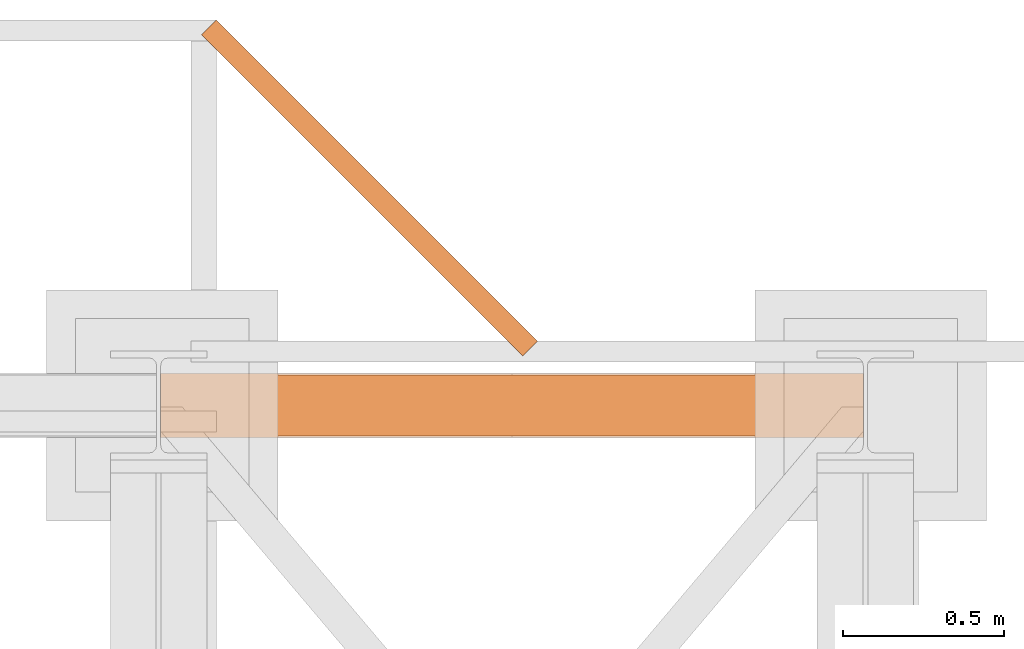
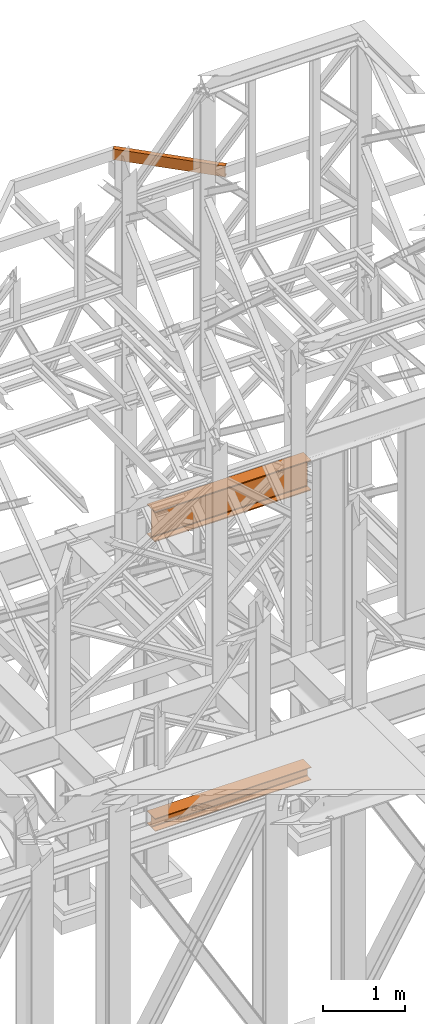
# One storey, part 197 of 208: 3 proxies.
"""IFC2X3 building model written with IfcOpenShell, lengths in millimetres."""

from ifc_helpers import new_model, entity, si_unit, converted_unit, frame, origin, origin_with_axes, place, context, subcontext, project, spatial, faceted_brep, element, save


model = new_model("IFC2X3")

# Units and contexts
model_context = context("Model", 3, precision=1e-05, world=origin())
plan_context = context("Plan", 3, precision=1e-05, world=origin())
body_context = subcontext(model_context, "Body", "Model", "MODEL_VIEW")
ifc_project = project(units=[si_unit("LENGTHUNIT", "METRE", prefix="MILLI"), converted_unit("PLANEANGLEUNIT", "DEGREE", entity("IfcPlaneAngleMeasure", 0.0174532925199433), si_unit("PLANEANGLEUNIT", "RADIAN"), dimensions=[0, 0, 0, 0, 0, 0, 0]), si_unit("AREAUNIT", "SQUARE_METRE"), si_unit("VOLUMEUNIT", "CUBIC_METRE")], contexts=[model_context, plan_context])

# Building, storey
building_placement = place(None, origin())
building = spatial("IfcBuilding", under=ifc_project, at=building_placement, CompositionType="COMPLEX")
storey_placement = place(building_placement, origin_with_axes())
storey = spatial("IfcBuildingStorey", under=building, at=storey_placement, Name="Geschoss", CompositionType="ELEMENT")

# Proxies
proxy_1_placement = place(storey_placement, frame((6599.254968580823, -12562.57439501764, 544.9900024165573), z_axis=(0.0, 0.0, 1.0), x_axis=(1.0, 0.0, 0.0)))
element("IfcBuildingElementProxy", 1, at=proxy_1_placement, inside=storey, context=body_context, shape_type="Brep", body=[
    faceted_brep([(2188.00999989569, 0.01000000000021828, 190.0100125169755), (2188.00999989569, 200.0100029802325, 190.0100125169755), (2188.00999989569, 200.0100029802325, 180.0100146031381), (2188.00999989569, 121.2600035762789, 180.0100071525575), (2188.00999989569, 111.9441915473344, 178.1454621052743), (2188.00999989569, 105.1245498640838, 171.3258190250398), (2188.00999989569, 103.2600015571716, 162.0100079274179), (2188.00999989569, 103.2600015571716, 28.00999713897716), (2188.00999989569, 105.1245498640838, 18.69418604135524), (2188.00999989569, 111.9441915473344, 11.87454296112071), (2188.00999989569, 121.2600035762789, 10.00999791383754), (2188.00999989569, 200.0100029802325, 10.00999791383754), (2188.00999989569, 200.0100029802325, 0.01000000000010459), (2188.00999989569, 0.01000000000021828, 0.01000000000010459), (2188.00999989569, 0.01000000000021828, 10.00999791383754), (2188.00999989569, 78.75999940395377, 10.00999791383754), (2188.00999989569, 88.07581143289826, 11.87454296112071), (2188.00999989569, 94.89545311614893, 18.69418604135524), (2188.00999989569, 96.76000142306111, 28.00999713897716), (2188.00999989569, 96.76000142306111, 162.0100079274179), (2188.00999989569, 94.89545311614893, 171.3258190250398), (2188.00999989569, 88.07581143289826, 178.1454621052743), (2188.00999989569, 78.75999940395377, 180.0100071525575), (2188.00999989569, 0.01000000000021828, 180.0100146031381), (2188.00999989569, 200.0100029802325, 190.0100125169755), (2188.00999989569, 0.01000000000021828, 190.0100125169755), (0.01000000000021828, 0.01000000000021828, 190.0100125169754), (0.01000000000021828, 200.0100029802325, 190.0100125169754), (2188.00999989569, 200.0100029802325, 180.0100146031381), (2188.00999989569, 200.0100029802325, 190.0100125169755), (0.01000000000021828, 200.0100029802325, 190.0100125169754), (0.01000000000021828, 200.0100029802325, 180.010014603138), (2188.00999989569, 121.2600035762789, 180.0100071525575), (2188.00999989569, 200.0100029802325, 180.0100146031381), (0.01000000000021828, 200.0100029802325, 180.010014603138), (0.01000000000021828, 121.2600035762789, 180.0100071525574), (2188.00999989569, 111.9441915473344, 178.1454621052743), (2188.00999989569, 121.2600035762789, 180.0100071525575), (0.01000000000021828, 121.2600035762789, 180.0100071525574), (0.01000000000021828, 111.9441915473344, 178.1454621052742), (2188.00999989569, 105.1245498640838, 171.3258190250398), (2188.00999989569, 111.9441915473344, 178.1454621052743), (0.01000000000021828, 111.9441915473344, 178.1454621052742), (0.01000000000021828, 105.1245498640838, 171.3258190250397), (2188.00999989569, 103.2600015571716, 162.0100079274179), (2188.00999989569, 105.1245498640838, 171.3258190250398), (0.01000000000021828, 105.1245498640838, 171.3258190250397), (0.01000000000021828, 103.2600015571716, 162.0100079274178), (2188.00999989569, 103.2600015571716, 28.00999713897716), (2188.00999989569, 103.2600015571716, 162.0100079274179), (0.01000000000021828, 103.2600015571716, 162.0100079274178), (0.01000000000021828, 103.2600015571716, 28.00999713897704), (2188.00999989569, 105.1245498640838, 18.69418604135524), (2188.00999989569, 103.2600015571716, 28.00999713897716), (0.01000000000021828, 103.2600015571716, 28.00999713897704), (0.01000000000021828, 105.1245498640838, 18.69418604135512), (2188.00999989569, 111.9441915473344, 11.87454296112071), (2188.00999989569, 105.1245498640838, 18.69418604135524), (0.01000000000021828, 105.1245498640838, 18.69418604135512), (0.01000000000021828, 111.9441915473344, 11.8745429611206), (2188.00999989569, 121.2600035762789, 10.00999791383754), (2188.00999989569, 111.9441915473344, 11.87454296112071), (0.01000000000021828, 111.9441915473344, 11.8745429611206), (0.01000000000021828, 121.2600035762789, 10.00999791383742), (2188.00999989569, 200.0100029802325, 10.00999791383754), (2188.00999989569, 121.2600035762789, 10.00999791383754), (0.01000000000021828, 121.2600035762789, 10.00999791383742), (0.01000000000021828, 200.0100029802325, 10.00999791383742), (2188.00999989569, 200.0100029802325, 0.01000000000010459), (2188.00999989569, 200.0100029802325, 10.00999791383754), (0.01000000000021828, 200.0100029802325, 10.00999791383742), (0.01000000000021828, 200.0100029802325, 0.009999999999990905), (2188.00999989569, 0.01000000000021828, 0.01000000000010459), (2188.00999989569, 200.0100029802325, 0.01000000000010459), (0.01000000000021828, 200.0100029802325, 0.009999999999990905), (0.01000000000021828, 0.01000000000021828, 0.009999999999990905), (2188.00999989569, 0.01000000000021828, 10.00999791383754), (2188.00999989569, 0.01000000000021828, 0.01000000000010459), (0.01000000000021828, 0.01000000000021828, 0.009999999999990905), (0.01000000000021828, 0.01000000000021828, 10.00999791383742), (2188.00999989569, 78.75999940395377, 10.00999791383754), (2188.00999989569, 0.01000000000021828, 10.00999791383754), (0.01000000000021828, 0.01000000000021828, 10.00999791383742), (0.01000000000021828, 78.75999940395377, 10.00999791383742), (2188.00999989569, 88.07581143289826, 11.87454296112071), (2188.00999989569, 78.75999940395377, 10.00999791383754), (0.01000000000021828, 78.75999940395377, 10.00999791383742), (0.01000000000021828, 88.07581143289826, 11.8745429611206), (2188.00999989569, 94.89545311614893, 18.69418604135524), (2188.00999989569, 88.07581143289826, 11.87454296112071), (0.01000000000021828, 88.07581143289826, 11.8745429611206), (0.01000000000021828, 94.89545311614893, 18.69418604135512), (2188.00999989569, 96.76000142306111, 28.00999713897716), (2188.00999989569, 94.89545311614893, 18.69418604135524), (0.01000000000021828, 94.89545311614893, 18.69418604135512), (0.01000000000021828, 96.76000142306111, 28.00999713897704), (2188.00999989569, 96.76000142306111, 162.0100079274179), (2188.00999989569, 96.76000142306111, 28.00999713897716), (0.01000000000021828, 96.76000142306111, 28.00999713897704), (0.01000000000021828, 96.76000142306111, 162.0100079274178), (2188.00999989569, 94.89545311614893, 171.3258190250398), (2188.00999989569, 96.76000142306111, 162.0100079274179), (0.01000000000021828, 96.76000142306111, 162.0100079274178), (0.01000000000021828, 94.89545311614893, 171.3258190250397), (2188.00999989569, 88.07581143289826, 178.1454621052743), (2188.00999989569, 94.89545311614893, 171.3258190250398), (0.01000000000021828, 94.89545311614893, 171.3258190250397), (0.01000000000021828, 88.07581143289826, 178.1454621052742), (2188.00999989569, 78.75999940395377, 180.0100071525575), (2188.00999989569, 88.07581143289826, 178.1454621052743), (0.01000000000021828, 88.07581143289826, 178.1454621052742), (0.01000000000021828, 78.75999940395377, 180.0100071525574), (2188.00999989569, 0.01000000000021828, 180.0100146031381), (2188.00999989569, 78.75999940395377, 180.0100071525575), (0.01000000000021828, 78.75999940395377, 180.0100071525574), (0.01000000000021828, 0.01000000000021828, 180.010014603138), (2188.00999989569, 0.01000000000021828, 190.0100125169755), (2188.00999989569, 0.01000000000021828, 180.0100146031381), (0.01000000000021828, 0.01000000000021828, 180.010014603138), (0.01000000000021828, 0.01000000000021828, 190.0100125169754), (0.01000000000021828, 0.01000000000021828, 190.0100125169754), (0.01000000000021828, 0.01000000000021828, 180.010014603138), (0.01000000000021828, 78.75999940395377, 180.0100071525574), (0.01000000000021828, 88.07581143289826, 178.1454621052742), (0.01000000000021828, 94.89545311614893, 171.3258190250397), (0.01000000000021828, 96.76000142306111, 162.0100079274178), (0.01000000000021828, 96.76000142306111, 28.00999713897704), (0.01000000000021828, 94.89545311614893, 18.69418604135512), (0.01000000000021828, 88.07581143289826, 11.8745429611206), (0.01000000000021828, 78.75999940395377, 10.00999791383742), (0.01000000000021828, 0.01000000000021828, 10.00999791383742), (0.01000000000021828, 0.01000000000021828, 0.009999999999990905), (0.01000000000021828, 200.0100029802325, 0.009999999999990905), (0.01000000000021828, 200.0100029802325, 10.00999791383742), (0.01000000000021828, 121.2600035762789, 10.00999791383742), (0.01000000000021828, 111.9441915473344, 11.8745429611206), (0.01000000000021828, 105.1245498640838, 18.69418604135512), (0.01000000000021828, 103.2600015571716, 28.00999713897704), (0.01000000000021828, 103.2600015571716, 162.0100079274178), (0.01000000000021828, 105.1245498640838, 171.3258190250397), (0.01000000000021828, 111.9441915473344, 178.1454621052742), (0.01000000000021828, 121.2600035762789, 180.0100071525574), (0.01000000000021828, 200.0100029802325, 180.010014603138), (0.01000000000021828, 200.0100029802325, 190.0100125169754)], [[[0, 1, 2, 3, 4, 5, 6, 7, 8, 9, 10, 11, 12, 13, 14, 15, 16, 17, 18, 19, 20, 21, 22, 23]], [[24, 25, 26, 27]], [[28, 29, 30, 31]], [[32, 33, 34, 35]], [[36, 37, 38, 39]], [[40, 41, 42, 43]], [[44, 45, 46, 47]], [[48, 49, 50, 51]], [[52, 53, 54, 55]], [[56, 57, 58, 59]], [[60, 61, 62, 63]], [[64, 65, 66, 67]], [[68, 69, 70, 71]], [[72, 73, 74, 75]], [[76, 77, 78, 79]], [[80, 81, 82, 83]], [[84, 85, 86, 87]], [[88, 89, 90, 91]], [[92, 93, 94, 95]], [[96, 97, 98, 99]], [[100, 101, 102, 103]], [[104, 105, 106, 107]], [[108, 109, 110, 111]], [[112, 113, 114, 115]], [[116, 117, 118, 119]], [[120, 121, 122, 123, 124, 125, 126, 127, 128, 129, 130, 131, 132, 133, 134, 135, 136, 137, 138, 139, 140, 141, 142, 143]]], orient=[[False], [False], [False], [False], [False], [False], [False], [False], [False], [False], [False], [False], [False], [False], [False], [False], [False], [False], [False], [False], [False], [False], [False], [False], [False], [False]]),
])
proxy_2_placement = place(storey_placement, frame((6599.254968580832, -12557.574399786, 4834.989987483023), z_axis=(0.0, 0.0, 1.0), x_axis=(1.0, 0.0, 0.0)))
element("IfcBuildingElementProxy", 2, at=proxy_2_placement, inside=storey, context=body_context, shape_type="Brep", body=[
    faceted_brep([(2188.009999895692, 0.00999999999839929, 450.0100178813937), (2188.009999895692, 190.0100125169738, 450.0100178813937), (2188.009999895692, 190.0100125169738, 435.4100240564349), (2188.009999895692, 120.7100073045476, 435.4100091552737), (2188.009999895692, 109.8415622657522, 433.2347078418734), (2188.009999895692, 101.8853126263603, 425.2784563398363), (2188.009999895692, 99.71000619068582, 414.4100113010409), (2188.009999895692, 99.71000619068582, 35.60999167919181), (2188.009999895692, 101.8853126263603, 24.74154664039634), (2188.009999895692, 109.8415622657522, 16.78529513835929), (2188.009999895692, 120.7100073045476, 14.60999382495902), (2188.009999895692, 190.0100125169738, 14.60999382495902), (2188.009999895692, 190.0100125169738, 0.01000000000021828), (2188.009999895692, 0.00999999999839929, 0.01000000000021828), (2188.009999895692, 0.00999999999839929, 14.60999382495902), (2188.009999895692, 69.31000521242458, 14.60999382495902), (2188.009999895692, 80.17845025122006, 16.78529513835929), (2188.009999895692, 88.13469989061196, 24.74154664039634), (2188.009999895692, 90.31000632628638, 35.60999167919181), (2188.009999895692, 90.31000632628638, 414.4100113010409), (2188.009999895692, 88.13469989061196, 425.2784563398363), (2188.009999895692, 80.17845025122006, 433.2347078418734), (2188.009999895692, 69.31000521242458, 435.4100091552737), (2188.009999895692, 0.00999999999839929, 435.4100240564349), (2188.009999895692, 190.0100125169738, 450.0100178813937), (2188.009999895692, 0.00999999999839929, 450.0100178813937), (0.01000000000021828, 0.01000000000021828, 450.0100178813937), (0.01000000000021828, 190.0100125169756, 450.0100178813937), (2188.009999895692, 190.0100125169738, 435.4100240564349), (2188.009999895692, 190.0100125169738, 450.0100178813937), (0.01000000000021828, 190.0100125169756, 450.0100178813937), (0.01000000000021828, 190.0100125169756, 435.4100240564349), (2188.009999895692, 120.7100073045476, 435.4100091552737), (2188.009999895692, 190.0100125169738, 435.4100240564349), (0.01000000000021828, 190.0100125169756, 435.4100240564349), (0.01000000000021828, 120.7100073045494, 435.4100091552737), (2188.009999895692, 109.8415622657522, 433.2347078418734), (2188.009999895692, 120.7100073045476, 435.4100091552737), (0.01000000000021828, 120.7100073045494, 435.4100091552737), (0.01000000000021828, 109.841562265754, 433.2347078418734), (2188.009999895692, 101.8853126263603, 425.2784563398363), (2188.009999895692, 109.8415622657522, 433.2347078418734), (0.01000000000021828, 109.841562265754, 433.2347078418734), (0.01000000000021828, 101.8853126263621, 425.2784563398363), (2188.009999895692, 99.71000619068582, 414.4100113010409), (2188.009999895692, 101.8853126263603, 425.2784563398363), (0.01000000000021828, 101.8853126263621, 425.2784563398363), (0.01000000000021828, 99.71000619068764, 414.4100113010409), (2188.009999895692, 99.71000619068582, 35.60999167919181), (2188.009999895692, 99.71000619068582, 414.4100113010409), (0.01000000000021828, 99.71000619068764, 414.4100113010409), (0.01000000000021828, 99.71000619068764, 35.60999167919181), (2188.009999895692, 101.8853126263603, 24.74154664039634), (2188.009999895692, 99.71000619068582, 35.60999167919181), (0.01000000000021828, 99.71000619068764, 35.60999167919181), (0.01000000000021828, 101.8853126263621, 24.74154664039634), (2188.009999895692, 109.8415622657522, 16.78529513835929), (2188.009999895692, 101.8853126263603, 24.74154664039634), (0.01000000000021828, 101.8853126263621, 24.74154664039634), (0.01000000000021828, 109.841562265754, 16.78529513835929), (2188.009999895692, 120.7100073045476, 14.60999382495902), (2188.009999895692, 109.8415622657522, 16.78529513835929), (0.01000000000021828, 109.841562265754, 16.78529513835929), (0.01000000000021828, 120.7100073045494, 14.60999382495902), (2188.009999895692, 190.0100125169738, 14.60999382495902), (2188.009999895692, 120.7100073045476, 14.60999382495902), (0.01000000000021828, 120.7100073045494, 14.60999382495902), (0.01000000000021828, 190.0100125169756, 14.60999382495902), (2188.009999895692, 190.0100125169738, 0.01000000000021828), (2188.009999895692, 190.0100125169738, 14.60999382495902), (0.01000000000021828, 190.0100125169756, 14.60999382495902), (0.01000000000021828, 190.0100125169756, 0.01000000000021828), (2188.009999895692, 0.00999999999839929, 0.01000000000021828), (2188.009999895692, 190.0100125169738, 0.01000000000021828), (0.01000000000021828, 190.0100125169756, 0.01000000000021828), (0.01000000000021828, 0.01000000000021828, 0.01000000000021828), (2188.009999895692, 0.00999999999839929, 14.60999382495902), (2188.009999895692, 0.00999999999839929, 0.01000000000021828), (0.01000000000021828, 0.01000000000021828, 0.01000000000021828), (0.01000000000021828, 0.01000000000021828, 14.60999382495902), (2188.009999895692, 69.31000521242458, 14.60999382495902), (2188.009999895692, 0.00999999999839929, 14.60999382495902), (0.01000000000021828, 0.01000000000021828, 14.60999382495902), (0.01000000000021828, 69.3100052124264, 14.60999382495902), (2188.009999895692, 80.17845025122006, 16.78529513835929), (2188.009999895692, 69.31000521242458, 14.60999382495902), (0.01000000000021828, 69.3100052124264, 14.60999382495902), (0.01000000000021828, 80.17845025122188, 16.78529513835929), (2188.009999895692, 88.13469989061196, 24.74154664039634), (2188.009999895692, 80.17845025122006, 16.78529513835929), (0.01000000000021828, 80.17845025122188, 16.78529513835929), (0.01000000000021828, 88.13469989061377, 24.74154664039634), (2188.009999895692, 90.31000632628638, 35.60999167919181), (2188.009999895692, 88.13469989061196, 24.74154664039634), (0.01000000000021828, 88.13469989061377, 24.74154664039634), (0.01000000000021828, 90.3100063262882, 35.60999167919181), (2188.009999895692, 90.31000632628638, 414.4100113010409), (2188.009999895692, 90.31000632628638, 35.60999167919181), (0.01000000000021828, 90.3100063262882, 35.60999167919181), (0.01000000000021828, 90.3100063262882, 414.4100113010409), (2188.009999895692, 88.13469989061196, 425.2784563398363), (2188.009999895692, 90.31000632628638, 414.4100113010409), (0.01000000000021828, 90.3100063262882, 414.4100113010409), (0.01000000000021828, 88.13469989061377, 425.2784563398363), (2188.009999895692, 80.17845025122006, 433.2347078418734), (2188.009999895692, 88.13469989061196, 425.2784563398363), (0.01000000000021828, 88.13469989061377, 425.2784563398363), (0.01000000000021828, 80.17845025122188, 433.2347078418734), (2188.009999895692, 69.31000521242458, 435.4100091552737), (2188.009999895692, 80.17845025122006, 433.2347078418734), (0.01000000000021828, 80.17845025122188, 433.2347078418734), (0.01000000000021828, 69.3100052124264, 435.4100091552737), (2188.009999895692, 0.00999999999839929, 435.4100240564349), (2188.009999895692, 69.31000521242458, 435.4100091552737), (0.01000000000021828, 69.3100052124264, 435.4100091552737), (0.01000000000021828, 0.01000000000021828, 435.4100240564349), (2188.009999895692, 0.00999999999839929, 450.0100178813937), (2188.009999895692, 0.00999999999839929, 435.4100240564349), (0.01000000000021828, 0.01000000000021828, 435.4100240564349), (0.01000000000021828, 0.01000000000021828, 450.0100178813937), (0.01000000000021828, 0.01000000000021828, 450.0100178813937), (0.01000000000021828, 0.01000000000021828, 435.4100240564349), (0.01000000000021828, 69.3100052124264, 435.4100091552737), (0.01000000000021828, 80.17845025122188, 433.2347078418734), (0.01000000000021828, 88.13469989061377, 425.2784563398363), (0.01000000000021828, 90.3100063262882, 414.4100113010409), (0.01000000000021828, 90.3100063262882, 35.60999167919181), (0.01000000000021828, 88.13469989061377, 24.74154664039634), (0.01000000000021828, 80.17845025122188, 16.78529513835929), (0.01000000000021828, 69.3100052124264, 14.60999382495902), (0.01000000000021828, 0.01000000000021828, 14.60999382495902), (0.01000000000021828, 0.01000000000021828, 0.01000000000021828), (0.01000000000021828, 190.0100125169756, 0.01000000000021828), (0.01000000000021828, 190.0100125169756, 14.60999382495902), (0.01000000000021828, 120.7100073045494, 14.60999382495902), (0.01000000000021828, 109.841562265754, 16.78529513835929), (0.01000000000021828, 101.8853126263621, 24.74154664039634), (0.01000000000021828, 99.71000619068764, 35.60999167919181), (0.01000000000021828, 99.71000619068764, 414.4100113010409), (0.01000000000021828, 101.8853126263621, 425.2784563398363), (0.01000000000021828, 109.841562265754, 433.2347078418734), (0.01000000000021828, 120.7100073045494, 435.4100091552737), (0.01000000000021828, 190.0100125169756, 435.4100240564349), (0.01000000000021828, 190.0100125169756, 450.0100178813937)], [[[0, 1, 2, 3, 4, 5, 6, 7, 8, 9, 10, 11, 12, 13, 14, 15, 16, 17, 18, 19, 20, 21, 22, 23]], [[24, 25, 26, 27]], [[28, 29, 30, 31]], [[32, 33, 34, 35]], [[36, 37, 38, 39]], [[40, 41, 42, 43]], [[44, 45, 46, 47]], [[48, 49, 50, 51]], [[52, 53, 54, 55]], [[56, 57, 58, 59]], [[60, 61, 62, 63]], [[64, 65, 66, 67]], [[68, 69, 70, 71]], [[72, 73, 74, 75]], [[76, 77, 78, 79]], [[80, 81, 82, 83]], [[84, 85, 86, 87]], [[88, 89, 90, 91]], [[92, 93, 94, 95]], [[96, 97, 98, 99]], [[100, 101, 102, 103]], [[104, 105, 106, 107]], [[108, 109, 110, 111]], [[112, 113, 114, 115]], [[116, 117, 118, 119]], [[120, 121, 122, 123, 124, 125, 126, 127, 128, 129, 130, 131, 132, 133, 134, 135, 136, 137, 138, 139, 140, 141, 142, 143]]], orient=[[False], [False], [False], [False], [False], [False], [False], [False], [False], [False], [False], [False], [False], [False], [False], [False], [False], [False], [False], [False], [False], [False], [False], [False], [False], [False]]),
])
proxy_3_placement = place(storey_placement, frame((6727.287533549237, -12308.53083325528, 9699.99), z_axis=(0.0, 0.0, 1.0), x_axis=(1.0, 0.0, 0.0)))
element("IfcBuildingElementProxy", 3, at=proxy_3_placement, inside=storey, context=body_context, shape_type="Brep", body=[
    faceted_brep([(45.97743646954586, 1045.966444427506, 0.01000000000021828), (1045.738309755405, 45.96644442750221, 0.01000000000021828), (1045.738309755405, 45.96644442750221, 3.132428070246533), (45.97743646954586, 1045.966444427506, 3.132428070246533), (45.97743646954586, 1045.966444427506, 3.132428070246533), (1045.738309755405, 45.96644442750221, 3.132428070246533), (1045.566648552481, 45.79482427335825, 4.748288908171162), (45.80577526662273, 1045.794824273362, 4.748288908171162), (45.80577526662273, 1045.794824273362, 4.748288908171162), (1045.566648552481, 45.79482427335825, 4.748288908171162), (1045.066854419561, 45.29514965456838, 6.221534443444398), (45.30598113370434, 1045.295149654572, 6.221534443444398), (45.30598113370434, 1045.295149654572, 6.221534443444398), (1045.066854419561, 45.29514965456838, 6.221534443444398), (1044.283017235056, 44.51149990647355, 7.422126703873801), (44.52214394919793, 1044.511499906475, 7.422126703873801), (44.52214394919793, 1044.511499906475, 7.422126703873801), (1044.283017235056, 44.51149990647355, 7.422126703873801), (1043.284325013841, 43.51304649924714, 8.244091391710754), (43.52345172798232, 1043.513046499251, 8.244091391710754), (43.52345172798232, 1043.513046499251, 8.244091391710754), (1043.284325013841, 43.51304649924714, 8.244091391710754), (1042.158930652823, 42.38792125008513, 8.614912102195376), (42.39805736696508, 1042.387921250089, 8.614912102195376), (42.39805736696508, 1042.387921250089, 8.614912102195376), (1042.158930652823, 42.38792125008513, 8.614912102195376), (1011.908168368042, 12.14439273069002, 12.0369859867169), (12.14729508218443, 1012.144392730694, 12.0369859867169), (12.14729508218443, 1012.144392730694, 12.0369859867169), (1011.908168368042, 12.14439273069002, 12.0369859867169), (1009.759688224282, 9.996426345926011, 12.74491643400506), (9.998814938422584, 1009.99642634593, 12.74491643400506), (9.998814938422584, 1009.99642634593, 12.74491643400506), (1009.759688224282, 9.996426345926011, 12.74491643400506), (1007.853093983779, 8.090288023038738, 14.31412174714933), (8.09222069792122, 1008.090288023042, 14.31412174714933), (8.09222069792122, 1008.090288023042, 14.31412174714933), (1007.853093983779, 8.090288023038738, 14.31412174714933), (1006.356677540633, 6.594229413040011, 16.60616151705835), (6.595804254773611, 1006.594229413044, 16.60616151705835), (6.595804254773611, 1006.594229413044, 16.60616151705835), (1006.356677540633, 6.594229413040011, 16.60616151705835), (1005.402525105061, 5.64030514080514, 19.41872117530875), (5.641651819201798, 1005.640305140807, 19.41872117530875), (5.641651819201798, 1005.640305140807, 19.41872117530875), (1005.402525105061, 5.64030514080514, 19.41872117530875), (1005.074808263114, 5.312666664709468, 22.50354641134618), (5.313934977255485, 1005.312666664713, 22.50354641134618), (5.313934977255485, 1005.312666664713, 22.50354641134618), (1005.074808263114, 5.312666664709468, 22.50354641134618), (1005.074808263114, 5.312666664709468, 137.5164535886524), (5.313934977255485, 1005.312666664713, 137.5164535886524), (5.313934977255485, 1005.312666664713, 137.5164535886524), (1005.074808263114, 5.312666664709468, 137.5164535886524), (1005.402525105061, 5.64030514080514, 140.6012788246917), (5.641651819201798, 1005.640305140807, 140.6012788246917), (5.641651819201798, 1005.640305140807, 140.6012788246917), (1005.402525105061, 5.64030514080514, 140.6012788246917), (1006.356677540633, 6.594229413040011, 143.4138384829403), (6.595804254773611, 1006.594229413044, 143.4138384829403), (6.595804254773611, 1006.594229413044, 143.4138384829403), (1006.356677540633, 6.594229413040011, 143.4138384829403), (1007.853093983779, 8.090288023038738, 145.7058782528493), (8.09222069792122, 1008.090288023042, 145.7058782528493), (8.09222069792122, 1008.090288023042, 145.7058782528493), (1007.853093983779, 8.090288023038738, 145.7058782528493), (1009.759688224282, 9.996426345926011, 147.2750835659936), (9.998814938422584, 1009.99642634593, 147.2750835659936), (9.998814938422584, 1009.99642634593, 147.2750835659936), (1009.759688224282, 9.996426345926011, 147.2750835659936), (1011.908168368042, 12.14439273069002, 147.9830140132817), (12.14729508218443, 1012.144392730694, 147.9830140132817), (12.14729508218443, 1012.144392730694, 147.9830140132817), (1011.908168368042, 12.14439273069002, 147.9830140132817), (1042.158930652823, 42.38792125008513, 151.4050878978032), (42.39805736696508, 1042.387921250089, 151.4050878978032), (42.39805736696508, 1042.387921250089, 151.4050878978032), (1042.158930652823, 42.38792125008513, 151.4050878978032), (1043.284325013841, 43.51304649924714, 151.7759086082879), (43.52345172798232, 1043.513046499251, 151.7759086082879), (43.52345172798232, 1043.513046499251, 151.7759086082879), (1043.284325013841, 43.51304649924714, 151.7759086082879), (1044.283017235056, 44.51149990647355, 152.5978732961248), (44.52214394919793, 1044.511499906475, 152.5978732961248), (44.52214394919793, 1044.511499906475, 152.5978732961248), (1044.283017235056, 44.51149990647355, 152.5978732961248), (1045.066854419561, 45.29514965456838, 153.7984655565542), (45.30598113370434, 1045.295149654572, 153.7984655565542), (45.30598113370434, 1045.295149654572, 153.7984655565542), (1045.066854419561, 45.29514965456838, 153.7984655565542), (1045.566648552481, 45.79482427335825, 155.2717110918275), (45.80577526662273, 1045.794824273362, 155.2717110918275), (45.80577526662273, 1045.794824273362, 155.2717110918275), (1045.566648552481, 45.79482427335825, 155.2717110918275), (1045.738309755405, 45.96644442750221, 156.8875719297521), (45.97743646954586, 1045.966444427506, 156.8875719297521), (45.97743646954586, 1045.966444427506, 156.8875719297521), (1045.738309755405, 45.96644442750221, 156.8875719297521), (1045.738309755405, 45.96644442750221, 160.0100000000002), (45.97743646954586, 1045.966444427506, 160.0100000000002), (45.97743646954586, 1045.966444427506, 160.0100000000002), (1045.738309755405, 45.96644442750221, 160.0100000000002), (999.7708732858591, 0.00999999999839929, 160.0100000000002), (0.01000000000021828, 1000.010000000002, 160.0100000000002), (0.01000000000021828, 1000.010000000002, 160.0100000000002), (999.7708732858591, 0.00999999999839929, 160.0100000000002), (999.7708732858591, 0.00999999999839929, 0.01000000000021828), (0.01000000000021828, 1000.010000000002, 0.01000000000021828), (0.01000000000021828, 1000.010000000002, 0.01000000000021828), (999.7708732858591, 0.00999999999839929, 0.01000000000021828), (1045.738309755405, 45.96644442750221, 0.01000000000021828), (45.97743646954586, 1045.966444427506, 0.01000000000021828), (45.97743646954586, 1045.966444427506, 0.01000000000021828), (45.97743646954586, 1045.966444427506, 3.132428070246533), (45.80577526662273, 1045.794824273362, 4.748288908171162), (45.30598113370434, 1045.295149654572, 6.221534443444398), (44.52214394919793, 1044.511499906475, 7.422126703873801), (43.52345172798232, 1043.513046499251, 8.244091391710754), (42.39805736696508, 1042.387921250089, 8.614912102195376), (12.14729508218443, 1012.144392730694, 12.0369859867169), (9.998814938422584, 1009.99642634593, 12.74491643400506), (8.09222069792122, 1008.090288023042, 14.31412174714933), (6.595804254773611, 1006.594229413044, 16.60616151705835), (5.641651819201798, 1005.640305140807, 19.41872117530875), (5.313934977255485, 1005.312666664713, 22.50354641134618), (5.313934977255485, 1005.312666664713, 137.5164535886524), (5.641651819201798, 1005.640305140807, 140.6012788246917), (6.595804254773611, 1006.594229413044, 143.4138384829403), (8.09222069792122, 1008.090288023042, 145.7058782528493), (9.998814938422584, 1009.99642634593, 147.2750835659936), (12.14729508218443, 1012.144392730694, 147.9830140132817), (42.39805736696508, 1042.387921250089, 151.4050878978032), (43.52345172798232, 1043.513046499251, 151.7759086082879), (44.52214394919793, 1044.511499906475, 152.5978732961248), (45.30598113370434, 1045.295149654572, 153.7984655565542), (45.80577526662273, 1045.794824273362, 155.2717110918275), (45.97743646954586, 1045.966444427506, 156.8875719297521), (45.97743646954586, 1045.966444427506, 160.0100000000002), (0.01000000000021828, 1000.010000000002, 160.0100000000002), (0.01000000000021828, 1000.010000000002, 0.01000000000021828), (1045.738309755405, 45.96644442750221, 0.01000000000021828), (999.7708732858591, 0.00999999999839929, 0.01000000000021828), (999.7708732858591, 0.00999999999839929, 160.0100000000002), (1045.738309755405, 45.96644442750221, 160.0100000000002), (1045.738309755405, 45.96644442750221, 156.8875719297521), (1045.566648552481, 45.79482427335825, 155.2717110918275), (1045.066854419561, 45.29514965456838, 153.7984655565542), (1044.283017235056, 44.51149990647355, 152.5978732961248), (1043.284325013841, 43.51304649924714, 151.7759086082879), (1042.158930652823, 42.38792125008513, 151.4050878978032), (1011.908168368042, 12.14439273069002, 147.9830140132817), (1009.759688224282, 9.996426345926011, 147.2750835659936), (1007.853093983779, 8.090288023038738, 145.7058782528493), (1006.356677540633, 6.594229413040011, 143.4138384829403), (1005.402525105061, 5.64030514080514, 140.6012788246917), (1005.074808263114, 5.312666664709468, 137.5164535886524), (1005.074808263114, 5.312666664709468, 22.50354641134618), (1005.402525105061, 5.64030514080514, 19.41872117530875), (1006.356677540633, 6.594229413040011, 16.60616151705835), (1007.853093983779, 8.090288023038738, 14.31412174714933), (1009.759688224282, 9.996426345926011, 12.74491643400506), (1011.908168368042, 12.14439273069002, 12.0369859867169), (1042.158930652823, 42.38792125008513, 8.614912102195376), (1043.284325013841, 43.51304649924714, 8.244091391710754), (1044.283017235056, 44.51149990647355, 7.422126703873801), (1045.066854419561, 45.29514965456838, 6.221534443444398), (1045.566648552481, 45.79482427335825, 4.748288908171162), (1045.738309755405, 45.96644442750221, 3.132428070246533)], [[[0, 1, 2, 3]], [[4, 5, 6, 7]], [[8, 9, 10, 11]], [[12, 13, 14, 15]], [[16, 17, 18, 19]], [[20, 21, 22, 23]], [[24, 25, 26, 27]], [[28, 29, 30, 31]], [[32, 33, 34, 35]], [[36, 37, 38, 39]], [[40, 41, 42, 43]], [[44, 45, 46, 47]], [[48, 49, 50, 51]], [[52, 53, 54, 55]], [[56, 57, 58, 59]], [[60, 61, 62, 63]], [[64, 65, 66, 67]], [[68, 69, 70, 71]], [[72, 73, 74, 75]], [[76, 77, 78, 79]], [[80, 81, 82, 83]], [[84, 85, 86, 87]], [[88, 89, 90, 91]], [[92, 93, 94, 95]], [[96, 97, 98, 99]], [[100, 101, 102, 103]], [[104, 105, 106, 107]], [[108, 109, 110, 111]], [[112, 113, 114, 115, 116, 117, 118, 119, 120, 121, 122, 123, 124, 125, 126, 127, 128, 129, 130, 131, 132, 133, 134, 135, 136, 137, 138, 139]], [[140, 141, 142, 143, 144, 145, 146, 147, 148, 149, 150, 151, 152, 153, 154, 155, 156, 157, 158, 159, 160, 161, 162, 163, 164, 165, 166, 167]]], orient=[[False], [False], [False], [False], [False], [False], [False], [False], [False], [False], [False], [False], [False], [False], [False], [False], [False], [False], [False], [False], [False], [False], [False], [False], [False], [False], [False], [False], [False], [False]]),
])

save(model, "model.ifc")
